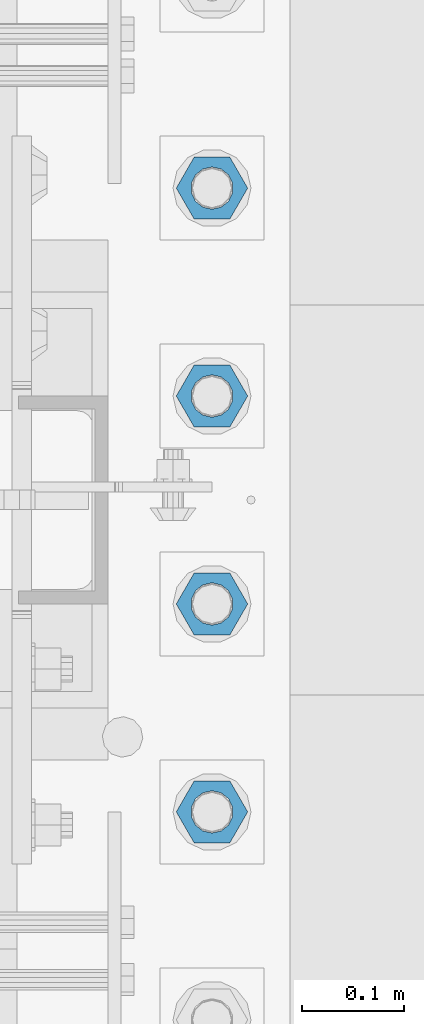
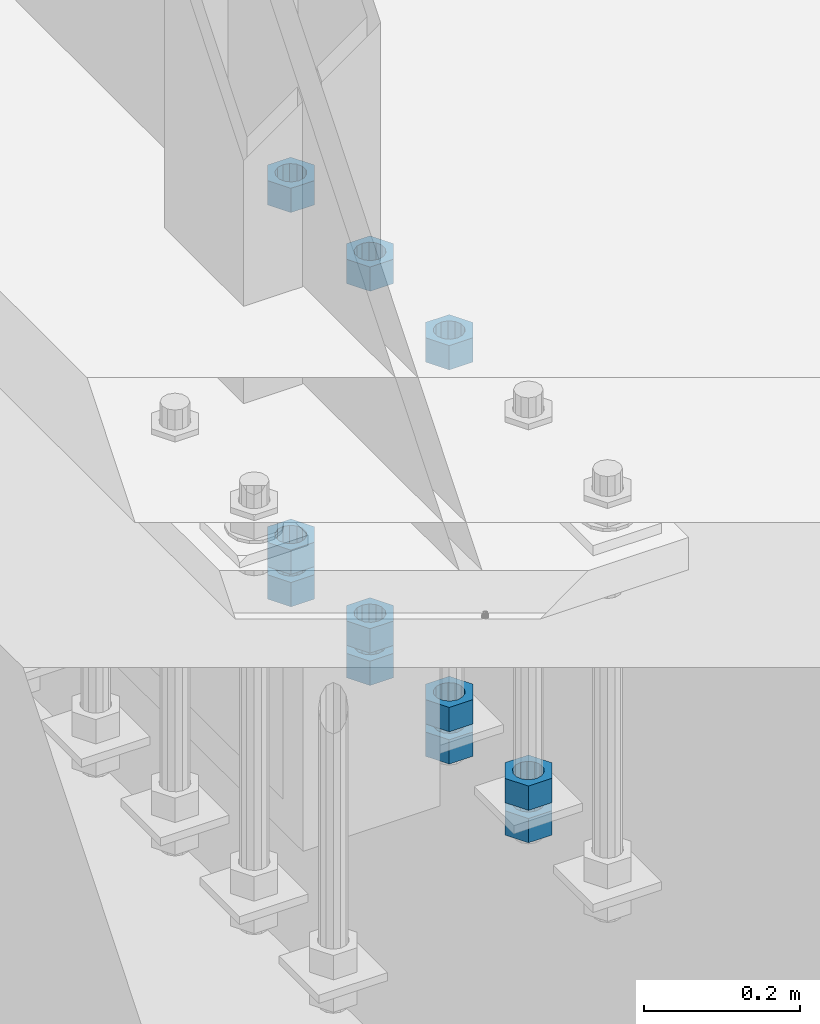
# One storey, part 986 of 1763: 11 columns, 1 element without a shape of its own.
"""IFC2X3 building model written with IfcOpenShell, lengths in millimetres."""

from ifc_helpers import new_model, si_unit, frame, origin_with_axes, place, context, subcontext, project, spatial, faceted_brep, material, type_object, element, aggregate, save


model = new_model("IFC2X3")

# Units and contexts
model_context = context("Model", 3, precision=1e-05, world=origin_with_axes())
body_context = subcontext(model_context, "Body", "Model", "MODEL_VIEW")
ifc_project = project(units=[si_unit("LENGTHUNIT", "METRE", prefix="MILLI"), si_unit("AREAUNIT", "SQUARE_METRE"), si_unit("VOLUMEUNIT", "CUBIC_METRE"), si_unit("MASSUNIT", "GRAM", prefix="KILO"), si_unit("TIMEUNIT", "SECOND"), si_unit("PLANEANGLEUNIT", "RADIAN"), si_unit("SOLIDANGLEUNIT", "STERADIAN"), si_unit("THERMODYNAMICTEMPERATUREUNIT", "DEGREE_CELSIUS"), si_unit("LUMINOUSINTENSITYUNIT", "LUMEN")], contexts=[model_context])

# Site, building, storey
site_placement = place(None, origin_with_axes())
site = spatial("IfcSite", under=ifc_project, at=site_placement, CompositionType="ELEMENT")
building_placement = place(site_placement, origin_with_axes())
building = spatial("IfcBuilding", under=site, at=building_placement, Name="Undefined", CompositionType="ELEMENT")
storey_placement = place(building_placement, origin_with_axes())
storey = spatial("IfcBuildingStorey", under=building, at=storey_placement, Name="Undefined", CompositionType="ELEMENT", Elevation=0.0)

# Assembly, columns
assembly_placement = place(storey_placement, origin_with_axes())
assembly = element("IfcElementAssembly", 1, at=assembly_placement, inside=storey, Name="TEMPLATE", AssemblyPlace="NOTDEFINED", PredefinedType="RIGID_FRAME")
ifc_material = material(Name="STEEL/A563")
column_type = type_object("IfcColumnType", Name="1-1/2_HEAVY_HEX_NUT", PredefinedType="NOTDEFINED")
column_1_placement = place(assembly_placement, frame((-87172.2372736984, 152.400000000001, 4622.8), z_axis=(0.0, 1.0, 0.0), x_axis=(0.0, 0.0, -1.0)))
column_1 = element("IfcColumn", 2, at=column_1_placement, type_object=column_type, material=ifc_material, Name="NUT", ObjectType="1-1/2_HEAVY_HEX_NUT", context=body_context, shape_type="Brep", body=[
    faceted_brep([(0.0, -34.9199981689453, 0.0), (0.0, -17.4599990844727, -30.25), (38.1000000000004, -17.4599990844727, -30.25), (38.1000000000004, -34.9199981689453, 0.0), (0.0, 17.4599990844727, -30.25), (38.1000000000004, 17.4599990844727, -30.25), (0.0, 34.9199981689453, 0.0), (38.1000000000004, 34.9199981689453, 0.0), (0.0, 17.4599990844727, 30.25), (38.1000000000004, 17.4599990844727, 30.25), (0.0, -17.4599990844727, 30.25), (38.1000000000004, -17.4599990844727, 30.25), (0.0, 0.0, 20.6399993896484), (0.0, 8.95536011056538, 18.5959968835978), (38.1000000000004, 8.95536011056538, 18.5959968835978), (38.1000000000004, 0.0, 20.6399993896484), (0.0, 16.1370013209453, 12.8688291298167), (38.1000000000004, 16.1370013209453, 12.8688291298167), (0.0, 20.1225115123816, 4.59283194104137), (38.1000000000004, 20.1225115123816, 4.59283194104137), (0.0, 20.1225115123816, -4.59283194104319), (38.1000000000004, 20.1225115123816, -4.59283194104319), (0.0, 16.1370013209453, -12.8688291298167), (38.1000000000004, 16.1370013209453, -12.8688291298167), (0.0, 8.95536011056538, -18.5959968835978), (38.1000000000004, 8.95536011056538, -18.5959968835978), (0.0, 0.0, -20.6399993896484), (38.1000000000004, 0.0, -20.6399993896484), (0.0, -8.95536011056538, -18.5959968835978), (38.1000000000004, -8.95536011056538, -18.5959968835978), (0.0, -16.1370013209453, -12.8688291298167), (38.1000000000004, -16.1370013209453, -12.8688291298167), (0.0, -20.1225115123816, -4.59283194104137), (38.1000000000004, -20.1225115123816, -4.59283194104137), (0.0, -20.1225115123816, 4.59283194104319), (38.1000000000004, -20.1225115123816, 4.59283194104319), (0.0, -16.1370013209453, 12.8688291298167), (38.1000000000004, -16.1370013209453, 12.8688291298167), (0.0, -8.95536011056538, 18.5959968835978), (38.1000000000004, -8.95536011056538, 18.5959968835978)], [[[0, 1, 2, 3]], [[1, 4, 5, 2]], [[4, 6, 7, 5]], [[6, 8, 9, 7]], [[8, 10, 11, 9]], [[10, 0, 3, 11]], [[12, 13, 14, 15]], [[13, 16, 17, 14]], [[16, 18, 19, 17]], [[18, 20, 21, 19]], [[20, 22, 23, 21]], [[22, 24, 25, 23]], [[24, 26, 27, 25]], [[26, 28, 29, 27]], [[28, 30, 31, 29]], [[30, 32, 33, 31]], [[32, 34, 35, 33]], [[34, 36, 37, 35]], [[36, 38, 39, 37]], [[38, 12, 15, 39]], [[5, 7, 9, 11, 3, 2], [17, 19, 21, 23, 25, 27, 29, 31, 33, 35, 37, 39, 15, 14]], [[10, 8, 6, 4, 1, 0], [38, 36, 34, 32, 30, 28, 26, 24, 22, 20, 18, 16, 13, 12]]]),
])
column_2_placement = place(assembly_placement, frame((-87172.2372736984, 152.400000000001, 4572.0), z_axis=(0.0, 1.0, 0.0), x_axis=(0.0, 0.0, -1.0)))
column_2 = element("IfcColumn", 3, at=column_2_placement, type_object=column_type, material=ifc_material, Name="NUT", ObjectType="1-1/2_HEAVY_HEX_NUT", context=body_context, shape_type="Brep", body=[
    faceted_brep([(0.0, -34.9199981689453, 0.0), (0.0, -17.4599990844727, -30.25), (38.1000000000004, -17.4599990844727, -30.25), (38.1000000000004, -34.9199981689453, 0.0), (0.0, 17.4599990844727, -30.25), (38.1000000000004, 17.4599990844727, -30.25), (0.0, 34.9199981689453, 0.0), (38.1000000000004, 34.9199981689453, 0.0), (0.0, 17.4599990844727, 30.25), (38.1000000000004, 17.4599990844727, 30.25), (0.0, -17.4599990844727, 30.25), (38.1000000000004, -17.4599990844727, 30.25), (0.0, 0.0, 20.6399993896484), (0.0, 8.95536011056538, 18.5959968835978), (38.1000000000004, 8.95536011056538, 18.5959968835978), (38.1000000000004, 0.0, 20.6399993896484), (0.0, 16.1370013209453, 12.8688291298167), (38.1000000000004, 16.1370013209453, 12.8688291298167), (0.0, 20.1225115123816, 4.59283194104137), (38.1000000000004, 20.1225115123816, 4.59283194104137), (0.0, 20.1225115123816, -4.59283194104319), (38.1000000000004, 20.1225115123816, -4.59283194104319), (0.0, 16.1370013209453, -12.8688291298167), (38.1000000000004, 16.1370013209453, -12.8688291298167), (0.0, 8.95536011056538, -18.5959968835978), (38.1000000000004, 8.95536011056538, -18.5959968835978), (0.0, 0.0, -20.6399993896484), (38.1000000000004, 0.0, -20.6399993896484), (0.0, -8.95536011056538, -18.5959968835978), (38.1000000000004, -8.95536011056538, -18.5959968835978), (0.0, -16.1370013209453, -12.8688291298167), (38.1000000000004, -16.1370013209453, -12.8688291298167), (0.0, -20.1225115123816, -4.59283194104137), (38.1000000000004, -20.1225115123816, -4.59283194104137), (0.0, -20.1225115123816, 4.59283194104319), (38.1000000000004, -20.1225115123816, 4.59283194104319), (0.0, -16.1370013209453, 12.8688291298167), (38.1000000000004, -16.1370013209453, 12.8688291298167), (0.0, -8.95536011056538, 18.5959968835978), (38.1000000000004, -8.95536011056538, 18.5959968835978)], [[[0, 1, 2, 3]], [[1, 4, 5, 2]], [[4, 6, 7, 5]], [[6, 8, 9, 7]], [[8, 10, 11, 9]], [[10, 0, 3, 11]], [[12, 13, 14, 15]], [[13, 16, 17, 14]], [[16, 18, 19, 17]], [[18, 20, 21, 19]], [[20, 22, 23, 21]], [[22, 24, 25, 23]], [[24, 26, 27, 25]], [[26, 28, 29, 27]], [[28, 30, 31, 29]], [[30, 32, 33, 31]], [[32, 34, 35, 33]], [[34, 36, 37, 35]], [[36, 38, 39, 37]], [[38, 12, 15, 39]], [[5, 7, 9, 11, 3, 2], [17, 19, 21, 23, 25, 27, 29, 31, 33, 35, 37, 39, 15, 14]], [[10, 8, 6, 4, 1, 0], [38, 36, 34, 32, 30, 28, 26, 24, 22, 20, 18, 16, 13, 12]]]),
])
column_3_placement = place(assembly_placement, frame((-87172.2372736984, 355.600000000001, 5189.5375), z_axis=(0.0, 1.0, 0.0), x_axis=(0.0, 0.0, -1.0)))
column_3 = element("IfcColumn", 4, at=column_3_placement, type_object=column_type, material=ifc_material, Name="NUT", ObjectType="1-1/2_HEAVY_HEX_NUT", context=body_context, shape_type="Brep", body=[
    faceted_brep([(0.0, -34.9199981689453, 0.0), (0.0, -17.4599990844727, -30.25), (38.1000000000004, -17.4599990844727, -30.25), (38.1000000000004, -34.9199981689453, 0.0), (0.0, 17.4599990844727, -30.25), (38.1000000000004, 17.4599990844727, -30.25), (0.0, 34.9199981689453, 0.0), (38.1000000000004, 34.9199981689453, 0.0), (0.0, 17.4599990844727, 30.25), (38.1000000000004, 17.4599990844727, 30.25), (0.0, -17.4599990844727, 30.25), (38.1000000000004, -17.4599990844727, 30.25), (0.0, 0.0, 20.6399993896484), (0.0, 8.95536011056538, 18.5959968835978), (38.1000000000004, 8.95536011056538, 18.5959968835978), (38.1000000000004, 0.0, 20.6399993896484), (0.0, 16.1370013209453, 12.8688291298167), (38.1000000000004, 16.1370013209453, 12.8688291298167), (0.0, 20.1225115123816, 4.59283194104137), (38.1000000000004, 20.1225115123816, 4.59283194104137), (0.0, 20.1225115123816, -4.59283194104319), (38.1000000000004, 20.1225115123816, -4.59283194104319), (0.0, 16.1370013209453, -12.8688291298167), (38.1000000000004, 16.1370013209453, -12.8688291298167), (0.0, 8.95536011056538, -18.5959968835978), (38.1000000000004, 8.95536011056538, -18.5959968835978), (0.0, 0.0, -20.6399993896484), (38.1000000000004, 0.0, -20.6399993896484), (0.0, -8.95536011056538, -18.5959968835978), (38.1000000000004, -8.95536011056538, -18.5959968835978), (0.0, -16.1370013209453, -12.8688291298167), (38.1000000000004, -16.1370013209453, -12.8688291298167), (0.0, -20.1225115123816, -4.59283194104137), (38.1000000000004, -20.1225115123816, -4.59283194104137), (0.0, -20.1225115123816, 4.59283194104319), (38.1000000000004, -20.1225115123816, 4.59283194104319), (0.0, -16.1370013209453, 12.8688291298167), (38.1000000000004, -16.1370013209453, 12.8688291298167), (0.0, -8.95536011056538, 18.5959968835978), (38.1000000000004, -8.95536011056538, 18.5959968835978)], [[[0, 1, 2, 3]], [[1, 4, 5, 2]], [[4, 6, 7, 5]], [[6, 8, 9, 7]], [[8, 10, 11, 9]], [[10, 0, 3, 11]], [[12, 13, 14, 15]], [[13, 16, 17, 14]], [[16, 18, 19, 17]], [[18, 20, 21, 19]], [[20, 22, 23, 21]], [[22, 24, 25, 23]], [[24, 26, 27, 25]], [[26, 28, 29, 27]], [[28, 30, 31, 29]], [[30, 32, 33, 31]], [[32, 34, 35, 33]], [[34, 36, 37, 35]], [[36, 38, 39, 37]], [[38, 12, 15, 39]], [[5, 7, 9, 11, 3, 2], [17, 19, 21, 23, 25, 27, 29, 31, 33, 35, 37, 39, 15, 14]], [[10, 8, 6, 4, 1, 0], [38, 36, 34, 32, 30, 28, 26, 24, 22, 20, 18, 16, 13, 12]]]),
])
column_4_placement = place(assembly_placement, frame((-87172.2372736984, 355.600000000001, 4622.8), z_axis=(0.0, 1.0, 0.0), x_axis=(0.0, 0.0, -1.0)))
column_4 = element("IfcColumn", 5, at=column_4_placement, type_object=column_type, material=ifc_material, Name="NUT", ObjectType="1-1/2_HEAVY_HEX_NUT", context=body_context, shape_type="Brep", body=[
    faceted_brep([(0.0, -34.9199981689453, 0.0), (0.0, -17.4599990844727, -30.25), (38.1000000000004, -17.4599990844727, -30.25), (38.1000000000004, -34.9199981689453, 0.0), (0.0, 17.4599990844727, -30.25), (38.1000000000004, 17.4599990844727, -30.25), (0.0, 34.9199981689453, 0.0), (38.1000000000004, 34.9199981689453, 0.0), (0.0, 17.4599990844727, 30.25), (38.1000000000004, 17.4599990844727, 30.25), (0.0, -17.4599990844727, 30.25), (38.1000000000004, -17.4599990844727, 30.25), (0.0, 0.0, 20.6399993896484), (0.0, 8.95536011056538, 18.5959968835978), (38.1000000000004, 8.95536011056538, 18.5959968835978), (38.1000000000004, 0.0, 20.6399993896484), (0.0, 16.1370013209453, 12.8688291298167), (38.1000000000004, 16.1370013209453, 12.8688291298167), (0.0, 20.1225115123816, 4.59283194104137), (38.1000000000004, 20.1225115123816, 4.59283194104137), (0.0, 20.1225115123816, -4.59283194104319), (38.1000000000004, 20.1225115123816, -4.59283194104319), (0.0, 16.1370013209453, -12.8688291298167), (38.1000000000004, 16.1370013209453, -12.8688291298167), (0.0, 8.95536011056538, -18.5959968835978), (38.1000000000004, 8.95536011056538, -18.5959968835978), (0.0, 0.0, -20.6399993896484), (38.1000000000004, 0.0, -20.6399993896484), (0.0, -8.95536011056538, -18.5959968835978), (38.1000000000004, -8.95536011056538, -18.5959968835978), (0.0, -16.1370013209453, -12.8688291298167), (38.1000000000004, -16.1370013209453, -12.8688291298167), (0.0, -20.1225115123816, -4.59283194104137), (38.1000000000004, -20.1225115123816, -4.59283194104137), (0.0, -20.1225115123816, 4.59283194104319), (38.1000000000004, -20.1225115123816, 4.59283194104319), (0.0, -16.1370013209453, 12.8688291298167), (38.1000000000004, -16.1370013209453, 12.8688291298167), (0.0, -8.95536011056538, 18.5959968835978), (38.1000000000004, -8.95536011056538, 18.5959968835978)], [[[0, 1, 2, 3]], [[1, 4, 5, 2]], [[4, 6, 7, 5]], [[6, 8, 9, 7]], [[8, 10, 11, 9]], [[10, 0, 3, 11]], [[12, 13, 14, 15]], [[13, 16, 17, 14]], [[16, 18, 19, 17]], [[18, 20, 21, 19]], [[20, 22, 23, 21]], [[22, 24, 25, 23]], [[24, 26, 27, 25]], [[26, 28, 29, 27]], [[28, 30, 31, 29]], [[30, 32, 33, 31]], [[32, 34, 35, 33]], [[34, 36, 37, 35]], [[36, 38, 39, 37]], [[38, 12, 15, 39]], [[5, 7, 9, 11, 3, 2], [17, 19, 21, 23, 25, 27, 29, 31, 33, 35, 37, 39, 15, 14]], [[10, 8, 6, 4, 1, 0], [38, 36, 34, 32, 30, 28, 26, 24, 22, 20, 18, 16, 13, 12]]]),
])
column_5_placement = place(assembly_placement, frame((-87172.2372736984, 355.600000000001, 4572.0), z_axis=(0.0, 1.0, 0.0), x_axis=(0.0, 0.0, -1.0)))
column_5 = element("IfcColumn", 6, at=column_5_placement, type_object=column_type, material=ifc_material, Name="NUT", ObjectType="1-1/2_HEAVY_HEX_NUT", context=body_context, shape_type="Brep", body=[
    faceted_brep([(0.0, -34.9199981689453, 0.0), (0.0, -17.4599990844727, -30.25), (38.1000000000004, -17.4599990844727, -30.25), (38.1000000000004, -34.9199981689453, 0.0), (0.0, 17.4599990844727, -30.25), (38.1000000000004, 17.4599990844727, -30.25), (0.0, 34.9199981689453, 0.0), (38.1000000000004, 34.9199981689453, 0.0), (0.0, 17.4599990844727, 30.25), (38.1000000000004, 17.4599990844727, 30.25), (0.0, -17.4599990844727, 30.25), (38.1000000000004, -17.4599990844727, 30.25), (0.0, 0.0, 20.6399993896484), (0.0, 8.95536011056538, 18.5959968835978), (38.1000000000004, 8.95536011056538, 18.5959968835978), (38.1000000000004, 0.0, 20.6399993896484), (0.0, 16.1370013209453, 12.8688291298167), (38.1000000000004, 16.1370013209453, 12.8688291298167), (0.0, 20.1225115123816, 4.59283194104137), (38.1000000000004, 20.1225115123816, 4.59283194104137), (0.0, 20.1225115123816, -4.59283194104319), (38.1000000000004, 20.1225115123816, -4.59283194104319), (0.0, 16.1370013209453, -12.8688291298167), (38.1000000000004, 16.1370013209453, -12.8688291298167), (0.0, 8.95536011056538, -18.5959968835978), (38.1000000000004, 8.95536011056538, -18.5959968835978), (0.0, 0.0, -20.6399993896484), (38.1000000000004, 0.0, -20.6399993896484), (0.0, -8.95536011056538, -18.5959968835978), (38.1000000000004, -8.95536011056538, -18.5959968835978), (0.0, -16.1370013209453, -12.8688291298167), (38.1000000000004, -16.1370013209453, -12.8688291298167), (0.0, -20.1225115123816, -4.59283194104137), (38.1000000000004, -20.1225115123816, -4.59283194104137), (0.0, -20.1225115123816, 4.59283194104319), (38.1000000000004, -20.1225115123816, 4.59283194104319), (0.0, -16.1370013209453, 12.8688291298167), (38.1000000000004, -16.1370013209453, 12.8688291298167), (0.0, -8.95536011056538, 18.5959968835978), (38.1000000000004, -8.95536011056538, 18.5959968835978)], [[[0, 1, 2, 3]], [[1, 4, 5, 2]], [[4, 6, 7, 5]], [[6, 8, 9, 7]], [[8, 10, 11, 9]], [[10, 0, 3, 11]], [[12, 13, 14, 15]], [[13, 16, 17, 14]], [[16, 18, 19, 17]], [[18, 20, 21, 19]], [[20, 22, 23, 21]], [[22, 24, 25, 23]], [[24, 26, 27, 25]], [[26, 28, 29, 27]], [[28, 30, 31, 29]], [[30, 32, 33, 31]], [[32, 34, 35, 33]], [[34, 36, 37, 35]], [[36, 38, 39, 37]], [[38, 12, 15, 39]], [[5, 7, 9, 11, 3, 2], [17, 19, 21, 23, 25, 27, 29, 31, 33, 35, 37, 39, 15, 14]], [[10, 8, 6, 4, 1, 0], [38, 36, 34, 32, 30, 28, 26, 24, 22, 20, 18, 16, 13, 12]]]),
])
column_6_placement = place(assembly_placement, frame((-87172.2372736984, 558.800000000001, 5189.5375), z_axis=(0.0, 1.0, 0.0), x_axis=(0.0, 0.0, -1.0)))
column_6 = element("IfcColumn", 7, at=column_6_placement, type_object=column_type, material=ifc_material, Name="NUT", ObjectType="1-1/2_HEAVY_HEX_NUT", context=body_context, shape_type="Brep", body=[
    faceted_brep([(0.0, -34.9199981689453, 0.0), (0.0, -17.4599990844727, -30.25), (38.1000000000004, -17.4599990844727, -30.25), (38.1000000000004, -34.9199981689453, 0.0), (0.0, 17.4599990844727, -30.25), (38.1000000000004, 17.4599990844727, -30.25), (0.0, 34.9199981689453, 0.0), (38.1000000000004, 34.9199981689453, 0.0), (0.0, 17.4599990844727, 30.25), (38.1000000000004, 17.4599990844727, 30.25), (0.0, -17.4599990844727, 30.25), (38.1000000000004, -17.4599990844727, 30.25), (0.0, 0.0, 20.6399993896484), (0.0, 8.95536011056538, 18.5959968835978), (38.1000000000004, 8.95536011056538, 18.5959968835978), (38.1000000000004, 0.0, 20.6399993896484), (0.0, 16.1370013209453, 12.8688291298167), (38.1000000000004, 16.1370013209453, 12.8688291298167), (0.0, 20.1225115123816, 4.59283194104137), (38.1000000000004, 20.1225115123816, 4.59283194104137), (0.0, 20.1225115123816, -4.59283194104319), (38.1000000000004, 20.1225115123816, -4.59283194104319), (0.0, 16.1370013209453, -12.8688291298167), (38.1000000000004, 16.1370013209453, -12.8688291298167), (0.0, 8.95536011056538, -18.5959968835978), (38.1000000000004, 8.95536011056538, -18.5959968835978), (0.0, 0.0, -20.6399993896484), (38.1000000000004, 0.0, -20.6399993896484), (0.0, -8.95536011056538, -18.5959968835978), (38.1000000000004, -8.95536011056538, -18.5959968835978), (0.0, -16.1370013209453, -12.8688291298167), (38.1000000000004, -16.1370013209453, -12.8688291298167), (0.0, -20.1225115123816, -4.59283194104137), (38.1000000000004, -20.1225115123816, -4.59283194104137), (0.0, -20.1225115123816, 4.59283194104319), (38.1000000000004, -20.1225115123816, 4.59283194104319), (0.0, -16.1370013209453, 12.8688291298167), (38.1000000000004, -16.1370013209453, 12.8688291298167), (0.0, -8.95536011056538, 18.5959968835978), (38.1000000000004, -8.95536011056538, 18.5959968835978)], [[[0, 1, 2, 3]], [[1, 4, 5, 2]], [[4, 6, 7, 5]], [[6, 8, 9, 7]], [[8, 10, 11, 9]], [[10, 0, 3, 11]], [[12, 13, 14, 15]], [[13, 16, 17, 14]], [[16, 18, 19, 17]], [[18, 20, 21, 19]], [[20, 22, 23, 21]], [[22, 24, 25, 23]], [[24, 26, 27, 25]], [[26, 28, 29, 27]], [[28, 30, 31, 29]], [[30, 32, 33, 31]], [[32, 34, 35, 33]], [[34, 36, 37, 35]], [[36, 38, 39, 37]], [[38, 12, 15, 39]], [[5, 7, 9, 11, 3, 2], [17, 19, 21, 23, 25, 27, 29, 31, 33, 35, 37, 39, 15, 14]], [[10, 8, 6, 4, 1, 0], [38, 36, 34, 32, 30, 28, 26, 24, 22, 20, 18, 16, 13, 12]]]),
])
column_7_placement = place(assembly_placement, frame((-87172.2372736984, 558.800000000001, 4622.8), z_axis=(0.0, 1.0, 0.0), x_axis=(0.0, 0.0, -1.0)))
column_7 = element("IfcColumn", 8, at=column_7_placement, type_object=column_type, material=ifc_material, Name="NUT", ObjectType="1-1/2_HEAVY_HEX_NUT", context=body_context, shape_type="Brep", body=[
    faceted_brep([(0.0, -34.9199981689453, 0.0), (0.0, -17.4599990844727, -30.25), (38.1000000000004, -17.4599990844727, -30.25), (38.1000000000004, -34.9199981689453, 0.0), (0.0, 17.4599990844727, -30.25), (38.1000000000004, 17.4599990844727, -30.25), (0.0, 34.9199981689453, 0.0), (38.1000000000004, 34.9199981689453, 0.0), (0.0, 17.4599990844727, 30.25), (38.1000000000004, 17.4599990844727, 30.25), (0.0, -17.4599990844727, 30.25), (38.1000000000004, -17.4599990844727, 30.25), (0.0, 0.0, 20.6399993896484), (0.0, 8.95536011056538, 18.5959968835978), (38.1000000000004, 8.95536011056538, 18.5959968835978), (38.1000000000004, 0.0, 20.6399993896484), (0.0, 16.1370013209453, 12.8688291298167), (38.1000000000004, 16.1370013209453, 12.8688291298167), (0.0, 20.1225115123816, 4.59283194104137), (38.1000000000004, 20.1225115123816, 4.59283194104137), (0.0, 20.1225115123816, -4.59283194104319), (38.1000000000004, 20.1225115123816, -4.59283194104319), (0.0, 16.1370013209453, -12.8688291298167), (38.1000000000004, 16.1370013209453, -12.8688291298167), (0.0, 8.95536011056538, -18.5959968835978), (38.1000000000004, 8.95536011056538, -18.5959968835978), (0.0, 0.0, -20.6399993896484), (38.1000000000004, 0.0, -20.6399993896484), (0.0, -8.95536011056538, -18.5959968835978), (38.1000000000004, -8.95536011056538, -18.5959968835978), (0.0, -16.1370013209453, -12.8688291298167), (38.1000000000004, -16.1370013209453, -12.8688291298167), (0.0, -20.1225115123816, -4.59283194104137), (38.1000000000004, -20.1225115123816, -4.59283194104137), (0.0, -20.1225115123816, 4.59283194104319), (38.1000000000004, -20.1225115123816, 4.59283194104319), (0.0, -16.1370013209453, 12.8688291298167), (38.1000000000004, -16.1370013209453, 12.8688291298167), (0.0, -8.95536011056538, 18.5959968835978), (38.1000000000004, -8.95536011056538, 18.5959968835978)], [[[0, 1, 2, 3]], [[1, 4, 5, 2]], [[4, 6, 7, 5]], [[6, 8, 9, 7]], [[8, 10, 11, 9]], [[10, 0, 3, 11]], [[12, 13, 14, 15]], [[13, 16, 17, 14]], [[16, 18, 19, 17]], [[18, 20, 21, 19]], [[20, 22, 23, 21]], [[22, 24, 25, 23]], [[24, 26, 27, 25]], [[26, 28, 29, 27]], [[28, 30, 31, 29]], [[30, 32, 33, 31]], [[32, 34, 35, 33]], [[34, 36, 37, 35]], [[36, 38, 39, 37]], [[38, 12, 15, 39]], [[5, 7, 9, 11, 3, 2], [17, 19, 21, 23, 25, 27, 29, 31, 33, 35, 37, 39, 15, 14]], [[10, 8, 6, 4, 1, 0], [38, 36, 34, 32, 30, 28, 26, 24, 22, 20, 18, 16, 13, 12]]]),
])
column_8_placement = place(assembly_placement, frame((-87172.2372736984, 558.800000000001, 4572.0), z_axis=(0.0, 1.0, 0.0), x_axis=(0.0, 0.0, -1.0)))
column_8 = element("IfcColumn", 9, at=column_8_placement, type_object=column_type, material=ifc_material, Name="NUT", ObjectType="1-1/2_HEAVY_HEX_NUT", context=body_context, shape_type="Brep", body=[
    faceted_brep([(0.0, -34.9199981689453, 0.0), (0.0, -17.4599990844727, -30.25), (38.1000000000004, -17.4599990844727, -30.25), (38.1000000000004, -34.9199981689453, 0.0), (0.0, 17.4599990844727, -30.25), (38.1000000000004, 17.4599990844727, -30.25), (0.0, 34.9199981689453, 0.0), (38.1000000000004, 34.9199981689453, 0.0), (0.0, 17.4599990844727, 30.25), (38.1000000000004, 17.4599990844727, 30.25), (0.0, -17.4599990844727, 30.25), (38.1000000000004, -17.4599990844727, 30.25), (0.0, 0.0, 20.6399993896484), (0.0, 8.95536011056538, 18.5959968835978), (38.1000000000004, 8.95536011056538, 18.5959968835978), (38.1000000000004, 0.0, 20.6399993896484), (0.0, 16.1370013209453, 12.8688291298167), (38.1000000000004, 16.1370013209453, 12.8688291298167), (0.0, 20.1225115123816, 4.59283194104137), (38.1000000000004, 20.1225115123816, 4.59283194104137), (0.0, 20.1225115123816, -4.59283194104319), (38.1000000000004, 20.1225115123816, -4.59283194104319), (0.0, 16.1370013209453, -12.8688291298167), (38.1000000000004, 16.1370013209453, -12.8688291298167), (0.0, 8.95536011056538, -18.5959968835978), (38.1000000000004, 8.95536011056538, -18.5959968835978), (0.0, 0.0, -20.6399993896484), (38.1000000000004, 0.0, -20.6399993896484), (0.0, -8.95536011056538, -18.5959968835978), (38.1000000000004, -8.95536011056538, -18.5959968835978), (0.0, -16.1370013209453, -12.8688291298167), (38.1000000000004, -16.1370013209453, -12.8688291298167), (0.0, -20.1225115123816, -4.59283194104137), (38.1000000000004, -20.1225115123816, -4.59283194104137), (0.0, -20.1225115123816, 4.59283194104319), (38.1000000000004, -20.1225115123816, 4.59283194104319), (0.0, -16.1370013209453, 12.8688291298167), (38.1000000000004, -16.1370013209453, 12.8688291298167), (0.0, -8.95536011056538, 18.5959968835978), (38.1000000000004, -8.95536011056538, 18.5959968835978)], [[[0, 1, 2, 3]], [[1, 4, 5, 2]], [[4, 6, 7, 5]], [[6, 8, 9, 7]], [[8, 10, 11, 9]], [[10, 0, 3, 11]], [[12, 13, 14, 15]], [[13, 16, 17, 14]], [[16, 18, 19, 17]], [[18, 20, 21, 19]], [[20, 22, 23, 21]], [[22, 24, 25, 23]], [[24, 26, 27, 25]], [[26, 28, 29, 27]], [[28, 30, 31, 29]], [[30, 32, 33, 31]], [[32, 34, 35, 33]], [[34, 36, 37, 35]], [[36, 38, 39, 37]], [[38, 12, 15, 39]], [[5, 7, 9, 11, 3, 2], [17, 19, 21, 23, 25, 27, 29, 31, 33, 35, 37, 39, 15, 14]], [[10, 8, 6, 4, 1, 0], [38, 36, 34, 32, 30, 28, 26, 24, 22, 20, 18, 16, 13, 12]]]),
])
column_9_placement = place(assembly_placement, frame((-87172.2372736984, 762.000000000001, 5189.5375), z_axis=(0.0, 1.0, 0.0), x_axis=(0.0, 0.0, -1.0)))
column_9 = element("IfcColumn", 10, at=column_9_placement, type_object=column_type, material=ifc_material, Name="NUT", ObjectType="1-1/2_HEAVY_HEX_NUT", context=body_context, shape_type="Brep", body=[
    faceted_brep([(0.0, -34.9199981689453, 0.0), (0.0, -17.4599990844727, -30.25), (38.1000000000004, -17.4599990844727, -30.25), (38.1000000000004, -34.9199981689453, 0.0), (0.0, 17.4599990844727, -30.25), (38.1000000000004, 17.4599990844727, -30.25), (0.0, 34.9199981689453, 0.0), (38.1000000000004, 34.9199981689453, 0.0), (0.0, 17.4599990844727, 30.25), (38.1000000000004, 17.4599990844727, 30.25), (0.0, -17.4599990844727, 30.25), (38.1000000000004, -17.4599990844727, 30.25), (0.0, 0.0, 20.6399993896484), (0.0, 8.95536011056538, 18.5959968835978), (38.1000000000004, 8.95536011056538, 18.5959968835978), (38.1000000000004, 0.0, 20.6399993896484), (0.0, 16.1370013209453, 12.8688291298167), (38.1000000000004, 16.1370013209453, 12.8688291298167), (0.0, 20.1225115123816, 4.59283194104137), (38.1000000000004, 20.1225115123816, 4.59283194104137), (0.0, 20.1225115123816, -4.59283194104319), (38.1000000000004, 20.1225115123816, -4.59283194104319), (0.0, 16.1370013209453, -12.8688291298167), (38.1000000000004, 16.1370013209453, -12.8688291298167), (0.0, 8.95536011056538, -18.5959968835978), (38.1000000000004, 8.95536011056538, -18.5959968835978), (0.0, 0.0, -20.6399993896484), (38.1000000000004, 0.0, -20.6399993896484), (0.0, -8.95536011056538, -18.5959968835978), (38.1000000000004, -8.95536011056538, -18.5959968835978), (0.0, -16.1370013209453, -12.8688291298167), (38.1000000000004, -16.1370013209453, -12.8688291298167), (0.0, -20.1225115123816, -4.59283194104137), (38.1000000000004, -20.1225115123816, -4.59283194104137), (0.0, -20.1225115123816, 4.59283194104319), (38.1000000000004, -20.1225115123816, 4.59283194104319), (0.0, -16.1370013209453, 12.8688291298167), (38.1000000000004, -16.1370013209453, 12.8688291298167), (0.0, -8.95536011056538, 18.5959968835978), (38.1000000000004, -8.95536011056538, 18.5959968835978)], [[[0, 1, 2, 3]], [[1, 4, 5, 2]], [[4, 6, 7, 5]], [[6, 8, 9, 7]], [[8, 10, 11, 9]], [[10, 0, 3, 11]], [[12, 13, 14, 15]], [[13, 16, 17, 14]], [[16, 18, 19, 17]], [[18, 20, 21, 19]], [[20, 22, 23, 21]], [[22, 24, 25, 23]], [[24, 26, 27, 25]], [[26, 28, 29, 27]], [[28, 30, 31, 29]], [[30, 32, 33, 31]], [[32, 34, 35, 33]], [[34, 36, 37, 35]], [[36, 38, 39, 37]], [[38, 12, 15, 39]], [[5, 7, 9, 11, 3, 2], [17, 19, 21, 23, 25, 27, 29, 31, 33, 35, 37, 39, 15, 14]], [[10, 8, 6, 4, 1, 0], [38, 36, 34, 32, 30, 28, 26, 24, 22, 20, 18, 16, 13, 12]]]),
])
column_10_placement = place(assembly_placement, frame((-87172.2372736984, 762.000000000001, 4622.8), z_axis=(0.0, 1.0, 0.0), x_axis=(0.0, 0.0, -1.0)))
column_10 = element("IfcColumn", 11, at=column_10_placement, type_object=column_type, material=ifc_material, Name="NUT", ObjectType="1-1/2_HEAVY_HEX_NUT", context=body_context, shape_type="Brep", body=[
    faceted_brep([(0.0, -34.9199981689453, 0.0), (0.0, -17.4599990844727, -30.25), (38.1000000000004, -17.4599990844727, -30.25), (38.1000000000004, -34.9199981689453, 0.0), (0.0, 17.4599990844727, -30.25), (38.1000000000004, 17.4599990844727, -30.25), (0.0, 34.9199981689453, 0.0), (38.1000000000004, 34.9199981689453, 0.0), (0.0, 17.4599990844727, 30.25), (38.1000000000004, 17.4599990844727, 30.25), (0.0, -17.4599990844727, 30.25), (38.1000000000004, -17.4599990844727, 30.25), (0.0, 0.0, 20.6399993896484), (0.0, 8.95536011056538, 18.5959968835978), (38.1000000000004, 8.95536011056538, 18.5959968835978), (38.1000000000004, 0.0, 20.6399993896484), (0.0, 16.1370013209453, 12.8688291298167), (38.1000000000004, 16.1370013209453, 12.8688291298167), (0.0, 20.1225115123816, 4.59283194104137), (38.1000000000004, 20.1225115123816, 4.59283194104137), (0.0, 20.1225115123816, -4.59283194104319), (38.1000000000004, 20.1225115123816, -4.59283194104319), (0.0, 16.1370013209453, -12.8688291298167), (38.1000000000004, 16.1370013209453, -12.8688291298167), (0.0, 8.95536011056538, -18.5959968835978), (38.1000000000004, 8.95536011056538, -18.5959968835978), (0.0, 0.0, -20.6399993896484), (38.1000000000004, 0.0, -20.6399993896484), (0.0, -8.95536011056538, -18.5959968835978), (38.1000000000004, -8.95536011056538, -18.5959968835978), (0.0, -16.1370013209453, -12.8688291298167), (38.1000000000004, -16.1370013209453, -12.8688291298167), (0.0, -20.1225115123816, -4.59283194104137), (38.1000000000004, -20.1225115123816, -4.59283194104137), (0.0, -20.1225115123816, 4.59283194104319), (38.1000000000004, -20.1225115123816, 4.59283194104319), (0.0, -16.1370013209453, 12.8688291298167), (38.1000000000004, -16.1370013209453, 12.8688291298167), (0.0, -8.95536011056538, 18.5959968835978), (38.1000000000004, -8.95536011056538, 18.5959968835978)], [[[0, 1, 2, 3]], [[1, 4, 5, 2]], [[4, 6, 7, 5]], [[6, 8, 9, 7]], [[8, 10, 11, 9]], [[10, 0, 3, 11]], [[12, 13, 14, 15]], [[13, 16, 17, 14]], [[16, 18, 19, 17]], [[18, 20, 21, 19]], [[20, 22, 23, 21]], [[22, 24, 25, 23]], [[24, 26, 27, 25]], [[26, 28, 29, 27]], [[28, 30, 31, 29]], [[30, 32, 33, 31]], [[32, 34, 35, 33]], [[34, 36, 37, 35]], [[36, 38, 39, 37]], [[38, 12, 15, 39]], [[5, 7, 9, 11, 3, 2], [17, 19, 21, 23, 25, 27, 29, 31, 33, 35, 37, 39, 15, 14]], [[10, 8, 6, 4, 1, 0], [38, 36, 34, 32, 30, 28, 26, 24, 22, 20, 18, 16, 13, 12]]]),
])
column_11_placement = place(assembly_placement, frame((-87172.2372736984, 762.000000000001, 4572.0), z_axis=(0.0, 1.0, 0.0), x_axis=(0.0, 0.0, -1.0)))
column_11 = element("IfcColumn", 12, at=column_11_placement, type_object=column_type, material=ifc_material, Name="NUT", ObjectType="1-1/2_HEAVY_HEX_NUT", context=body_context, shape_type="Brep", body=[
    faceted_brep([(0.0, -34.9199981689453, 0.0), (0.0, -17.4599990844727, -30.25), (38.1000000000004, -17.4599990844727, -30.25), (38.1000000000004, -34.9199981689453, 0.0), (0.0, 17.4599990844727, -30.25), (38.1000000000004, 17.4599990844727, -30.25), (0.0, 34.9199981689453, 0.0), (38.1000000000004, 34.9199981689453, 0.0), (0.0, 17.4599990844727, 30.25), (38.1000000000004, 17.4599990844727, 30.25), (0.0, -17.4599990844727, 30.25), (38.1000000000004, -17.4599990844727, 30.25), (0.0, 0.0, 20.6399993896484), (0.0, 8.95536011056538, 18.5959968835978), (38.1000000000004, 8.95536011056538, 18.5959968835978), (38.1000000000004, 0.0, 20.6399993896484), (0.0, 16.1370013209453, 12.8688291298167), (38.1000000000004, 16.1370013209453, 12.8688291298167), (0.0, 20.1225115123816, 4.59283194104137), (38.1000000000004, 20.1225115123816, 4.59283194104137), (0.0, 20.1225115123816, -4.59283194104319), (38.1000000000004, 20.1225115123816, -4.59283194104319), (0.0, 16.1370013209453, -12.8688291298167), (38.1000000000004, 16.1370013209453, -12.8688291298167), (0.0, 8.95536011056538, -18.5959968835978), (38.1000000000004, 8.95536011056538, -18.5959968835978), (0.0, 0.0, -20.6399993896484), (38.1000000000004, 0.0, -20.6399993896484), (0.0, -8.95536011056538, -18.5959968835978), (38.1000000000004, -8.95536011056538, -18.5959968835978), (0.0, -16.1370013209453, -12.8688291298167), (38.1000000000004, -16.1370013209453, -12.8688291298167), (0.0, -20.1225115123816, -4.59283194104137), (38.1000000000004, -20.1225115123816, -4.59283194104137), (0.0, -20.1225115123816, 4.59283194104319), (38.1000000000004, -20.1225115123816, 4.59283194104319), (0.0, -16.1370013209453, 12.8688291298167), (38.1000000000004, -16.1370013209453, 12.8688291298167), (0.0, -8.95536011056538, 18.5959968835978), (38.1000000000004, -8.95536011056538, 18.5959968835978)], [[[0, 1, 2, 3]], [[1, 4, 5, 2]], [[4, 6, 7, 5]], [[6, 8, 9, 7]], [[8, 10, 11, 9]], [[10, 0, 3, 11]], [[12, 13, 14, 15]], [[13, 16, 17, 14]], [[16, 18, 19, 17]], [[18, 20, 21, 19]], [[20, 22, 23, 21]], [[22, 24, 25, 23]], [[24, 26, 27, 25]], [[26, 28, 29, 27]], [[28, 30, 31, 29]], [[30, 32, 33, 31]], [[32, 34, 35, 33]], [[34, 36, 37, 35]], [[36, 38, 39, 37]], [[38, 12, 15, 39]], [[5, 7, 9, 11, 3, 2], [17, 19, 21, 23, 25, 27, 29, 31, 33, 35, 37, 39, 15, 14]], [[10, 8, 6, 4, 1, 0], [38, 36, 34, 32, 30, 28, 26, 24, 22, 20, 18, 16, 13, 12]]]),
])
aggregate(assembly, [column_1, column_2, column_3, column_4, column_5, column_6, column_7, column_8, column_9, column_10, column_11])

save(model, "model.ifc")
